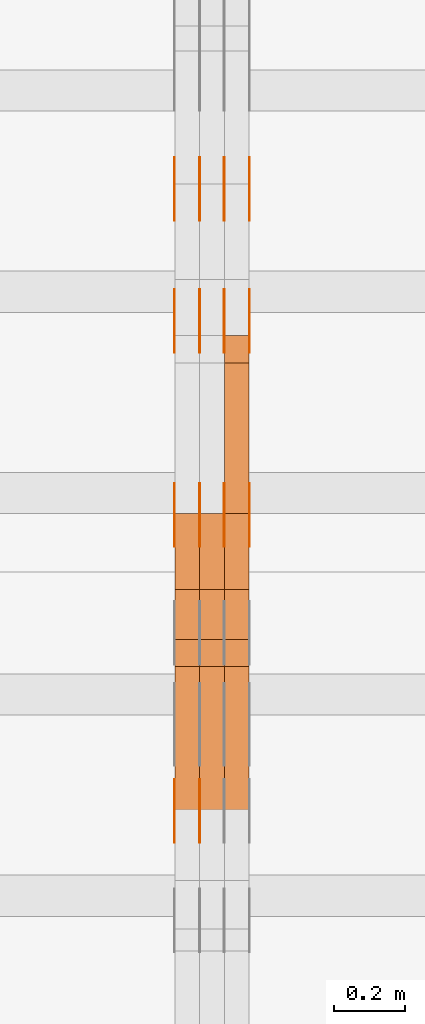
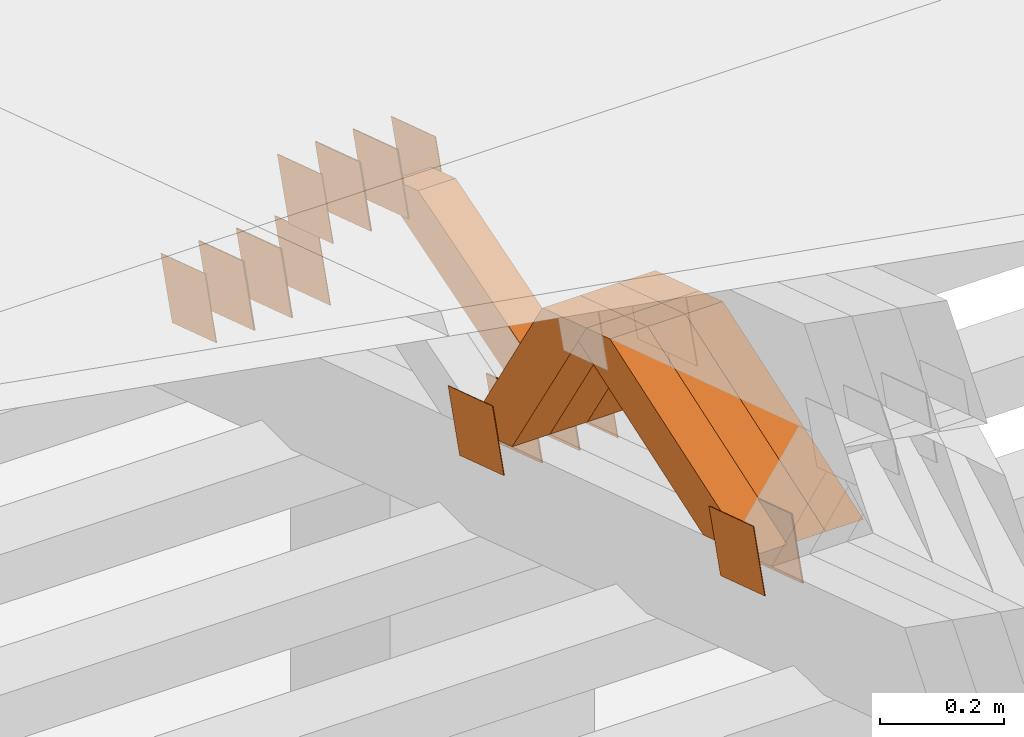
# One storey, part 356 of 385: 28 proxies.
"""IFC2X3 building model written with IfcOpenShell, lengths in millimetres."""

from ifc_helpers import new_model, entity, si_unit, converted_unit, derived_unit, direction, frame, origin, place, context, subcontext, project, spatial, polyline, outline, extrude, source, transform, mapped, material, type_object, type_shapes, element, save


model = new_model("IFC2X3")

# Units and contexts
model_context = context("Model", 3, precision=0.01, world=origin(), true_north=direction((6.12303176911189e-17, 1.0)))
body_context = subcontext(model_context, "Body", "Model", "MODEL_VIEW")
ifc_project = project(units=[si_unit("LENGTHUNIT", "METRE", prefix="MILLI"), si_unit("AREAUNIT", "SQUARE_METRE"), si_unit("VOLUMEUNIT", "CUBIC_METRE"), converted_unit("PLANEANGLEUNIT", "DEGREE", entity("IfcRatioMeasure", 0.0174532925199433), si_unit("PLANEANGLEUNIT", "RADIAN"), dimensions=[0, 0, 0, 0, 0, 0, 0]), si_unit("MASSUNIT", "GRAM", prefix="KILO"), derived_unit("MASSDENSITYUNIT", [(si_unit("MASSUNIT", "GRAM", prefix="KILO"), 1), (si_unit("LENGTHUNIT", "METRE"), -3)]), si_unit("TIMEUNIT", "SECOND"), si_unit("FREQUENCYUNIT", "HERTZ"), si_unit("THERMODYNAMICTEMPERATUREUNIT", "DEGREE_CELSIUS"), derived_unit("THERMALTRANSMITTANCEUNIT", [(si_unit("MASSUNIT", "GRAM", prefix="KILO"), 1), (si_unit("THERMODYNAMICTEMPERATUREUNIT", "KELVIN"), -1), (si_unit("TIMEUNIT", "SECOND"), -3)]), derived_unit("VOLUMETRICFLOWRATEUNIT", [(si_unit("LENGTHUNIT", "METRE"), 3), (si_unit("TIMEUNIT", "SECOND"), -1)]), si_unit("ELECTRICCURRENTUNIT", "AMPERE"), si_unit("ELECTRICVOLTAGEUNIT", "VOLT"), si_unit("POWERUNIT", "WATT"), si_unit("FORCEUNIT", "NEWTON", prefix="KILO"), si_unit("ILLUMINANCEUNIT", "LUX"), si_unit("LUMINOUSFLUXUNIT", "LUMEN"), si_unit("LUMINOUSINTENSITYUNIT", "CANDELA"), derived_unit("USERDEFINED", [(si_unit("MASSUNIT", "GRAM", prefix="KILO"), -1), (si_unit("LENGTHUNIT", "METRE"), -2), (si_unit("TIMEUNIT", "SECOND"), 3), (si_unit("LUMINOUSFLUXUNIT", "LUMEN"), 1)]), derived_unit("LINEARVELOCITYUNIT", [(si_unit("LENGTHUNIT", "METRE"), 1), (si_unit("TIMEUNIT", "SECOND"), -1)]), si_unit("PRESSUREUNIT", "PASCAL"), derived_unit("USERDEFINED", [(si_unit("LENGTHUNIT", "METRE"), -2), (si_unit("MASSUNIT", "GRAM", prefix="KILO"), 1), (si_unit("TIMEUNIT", "SECOND"), -2)])], contexts=[model_context])

# Site, building, storey
site_placement = place(None, origin())
site = spatial("IfcSite", under=ifc_project, at=site_placement, CompositionType="ELEMENT")
building_placement = place(site_placement, origin())
building = spatial("IfcBuilding", under=site, at=building_placement, CompositionType="ELEMENT")
storey_placement = place(building_placement, origin())
storey = spatial("IfcBuildingStorey", under=building, at=storey_placement, Name="Default", CompositionType="ELEMENT", Elevation=0.0)

# Proxies
ifc_material_1 = material(Name="IfcSurfaceStyle #548159")
building_element_proxy_type_1 = type_object("IfcBuildingElementProxyType", PredefinedType="NOTDEFINED", material=ifc_material_1)
shared_shape_1 = source(origin(), body_context, "Body", "SweptSolid", [
    extrude(outline(polyline([(-74.9998605591118, -59.9999264677598), (74.9998754286171, -59.9999264677598), (74.9998605591136, 59.9999264677598), (-74.9998754286189, 59.9999264677598), (-74.9998605591118, -59.9999264677598)])), frame((75.0000347664736, 60.0000016373434, 0.0), z_axis=(0.0, 0.0, 1.0), x_axis=(-1.0, 0.0, 0.0)), (0.0, 0.0, 1.0), 1.29999999999999),
])
type_shapes(building_element_proxy_type_1, [shared_shape_1])
proxy_1_placement = place(building_placement, frame((45245.0, 20117.0890328686, 2105.40814929196), z_axis=(-1.0, 0.0, 0.0), x_axis=(0.0, -0.951056516295124, 0.309016994375039)))
element("IfcBuildingElementProxy", 1, at=proxy_1_placement, inside=storey, type_object=building_element_proxy_type_1, material=ifc_material_1, context=body_context, shape_type="MappedRepresentation", body=[
    mapped(shared_shape_1, transform((0.0, 0.0, 0.0), scale=1.0)),
])
ifc_material_2 = material(Name="IfcSurfaceStyle #548102")
building_element_proxy_type_2 = type_object("IfcBuildingElementProxyType", PredefinedType="NOTDEFINED", material=ifc_material_2)
shared_shape_2 = source(origin(), body_context, "Body", "SweptSolid", [
    extrude(outline(polyline([(-74.9998605591118, -59.9999264677598), (74.9998754286171, -59.9999264677598), (74.9998605591136, 59.9999264677598), (-74.9998754286189, 59.9999264677598), (-74.9998605591118, -59.9999264677598)])), frame((75.0000347664736, 60.0000016373434, 0.0), z_axis=(0.0, 0.0, 1.0), x_axis=(-1.0, 0.0, 0.0)), (0.0, 0.0, 1.0), 1.29999999999999),
])
type_shapes(building_element_proxy_type_2, [shared_shape_2])
proxy_2_placement = place(building_placement, frame((45246.3, 20117.0890328686, 2105.40814929196), z_axis=(-1.0, 0.0, 0.0), x_axis=(0.0, -0.951056516295124, 0.309016994375039)))
element("IfcBuildingElementProxy", 2, at=proxy_2_placement, inside=storey, type_object=building_element_proxy_type_2, material=ifc_material_2, context=body_context, shape_type="MappedRepresentation", body=[
    mapped(shared_shape_2, transform((0.0, 0.0, 0.0), scale=1.0)),
])
ifc_material_3 = material(Name="IfcSurfaceStyle #548045")
building_element_proxy_type_3 = type_object("IfcBuildingElementProxyType", PredefinedType="NOTDEFINED", material=ifc_material_3)
shared_shape_3 = source(origin(), body_context, "Body", "SweptSolid", [
    extrude(outline(polyline([(-74.9998605591118, -59.9999264677598), (74.9998754286171, -59.9999264677598), (74.9998605591136, 59.9999264677598), (-74.9998754286189, 59.9999264677598), (-74.9998605591118, -59.9999264677598)])), frame((75.0000347664736, 60.0000016373434, 0.0), z_axis=(0.0, 0.0, 1.0), x_axis=(-1.0, 0.0, 0.0)), (0.0, 0.0, 1.0), 1.29999999999999),
])
type_shapes(building_element_proxy_type_3, [shared_shape_3])
proxy_3_placement = place(building_placement, frame((45175.0, 20117.0890328686, 2105.40814929196), z_axis=(-1.0, 0.0, 0.0), x_axis=(0.0, -0.951056516295124, 0.309016994375039)))
element("IfcBuildingElementProxy", 3, at=proxy_3_placement, inside=storey, type_object=building_element_proxy_type_3, material=ifc_material_3, context=body_context, shape_type="MappedRepresentation", body=[
    mapped(shared_shape_3, transform((0.0, 0.0, 0.0), scale=1.0)),
])
ifc_material_4 = material(Name="IfcSurfaceStyle #547988")
building_element_proxy_type_4 = type_object("IfcBuildingElementProxyType", PredefinedType="NOTDEFINED", material=ifc_material_4)
shared_shape_4 = source(origin(), body_context, "Body", "SweptSolid", [
    extrude(outline(polyline([(-74.9998794200132, -59.999984515643), (74.9998565677174, -59.999984515643), (74.9998794200123, 59.999984515643), (-74.9998565677165, 59.999984515643), (-74.9998794200132, -59.999984515643)])), frame((75.0002235343086, 60.0000596852268, 0.0), z_axis=(0.0, 0.0, 1.0), x_axis=(-1.0, 0.0, 0.0)), (0.0, 0.0, 1.0), 1.3),
])
type_shapes(building_element_proxy_type_4, [shared_shape_4])
proxy_4_placement = place(building_placement, frame((45386.3, 20956.2317725847, 1832.75404405346), z_axis=(-1.0, 0.0, 0.0), x_axis=(0.0, -0.951056516295124, 0.309016994375039)))
element("IfcBuildingElementProxy", 4, at=proxy_4_placement, inside=storey, type_object=building_element_proxy_type_4, material=ifc_material_4, context=body_context, shape_type="MappedRepresentation", body=[
    mapped(shared_shape_4, transform((0.0, 0.0, 0.0), scale=1.0)),
])
ifc_material_5 = material(Name="IfcSurfaceStyle #547931")
building_element_proxy_type_5 = type_object("IfcBuildingElementProxyType", PredefinedType="NOTDEFINED", material=ifc_material_5)
shared_shape_5 = source(origin(), body_context, "Body", "SweptSolid", [
    extrude(outline(polyline([(-74.9998794200132, -59.999984515643), (74.9998565677174, -59.999984515643), (74.9998794200123, 59.999984515643), (-74.9998565677165, 59.999984515643), (-74.9998794200132, -59.999984515643)])), frame((75.0002235343086, 60.0000596852268, 0.0), z_axis=(0.0, 0.0, 1.0), x_axis=(-1.0, 0.0, 0.0)), (0.0, 0.0, 1.0), 1.3),
])
type_shapes(building_element_proxy_type_5, [shared_shape_5])
proxy_5_placement = place(building_placement, frame((45315.0, 20956.2317725847, 1832.75404405346), z_axis=(-1.0, 0.0, 0.0), x_axis=(0.0, -0.951056516295124, 0.309016994375039)))
element("IfcBuildingElementProxy", 5, at=proxy_5_placement, inside=storey, type_object=building_element_proxy_type_5, material=ifc_material_5, context=body_context, shape_type="MappedRepresentation", body=[
    mapped(shared_shape_5, transform((0.0, 0.0, 0.0), scale=1.0)),
])
ifc_material_6 = material(Name="IfcSurfaceStyle #547874")
building_element_proxy_type_6 = type_object("IfcBuildingElementProxyType", PredefinedType="NOTDEFINED", material=ifc_material_6)
shared_shape_6 = source(origin(), body_context, "Body", "SweptSolid", [
    extrude(outline(polyline([(-74.9998794200132, -59.999984515643), (74.9998565677174, -59.999984515643), (74.9998794200123, 59.999984515643), (-74.9998565677165, 59.999984515643), (-74.9998794200132, -59.999984515643)])), frame((75.0002235343086, 60.0000596852268, 0.0), z_axis=(0.0, 0.0, 1.0), x_axis=(-1.0, 0.0, 0.0)), (0.0, 0.0, 1.0), 1.3),
])
type_shapes(building_element_proxy_type_6, [shared_shape_6])
proxy_6_placement = place(building_placement, frame((45316.3, 20956.2317725847, 1832.75404405346), z_axis=(-1.0, 0.0, 0.0), x_axis=(0.0, -0.951056516295124, 0.309016994375039)))
element("IfcBuildingElementProxy", 6, at=proxy_6_placement, inside=storey, type_object=building_element_proxy_type_6, material=ifc_material_6, context=body_context, shape_type="MappedRepresentation", body=[
    mapped(shared_shape_6, transform((0.0, 0.0, 0.0), scale=1.0)),
])
ifc_material_7 = material(Name="IfcSurfaceStyle #547817")
building_element_proxy_type_7 = type_object("IfcBuildingElementProxyType", PredefinedType="NOTDEFINED", material=ifc_material_7)
shared_shape_7 = source(origin(), body_context, "Body", "SweptSolid", [
    extrude(outline(polyline([(-74.9998794200132, -59.999984515643), (74.9998565677174, -59.999984515643), (74.9998794200123, 59.999984515643), (-74.9998565677165, 59.999984515643), (-74.9998794200132, -59.999984515643)])), frame((75.0002235343086, 60.0000596852268, 0.0), z_axis=(0.0, 0.0, 1.0), x_axis=(-1.0, 0.0, 0.0)), (0.0, 0.0, 1.0), 1.29999999999999),
])
type_shapes(building_element_proxy_type_7, [shared_shape_7])
proxy_7_placement = place(building_placement, frame((45245.0, 20956.2317725847, 1832.75404405346), z_axis=(-1.0, 0.0, 0.0), x_axis=(0.0, -0.951056516295124, 0.309016994375039)))
element("IfcBuildingElementProxy", 7, at=proxy_7_placement, inside=storey, type_object=building_element_proxy_type_7, material=ifc_material_7, context=body_context, shape_type="MappedRepresentation", body=[
    mapped(shared_shape_7, transform((0.0, 0.0, 0.0), scale=1.0)),
])
ifc_material_8 = material(Name="IfcSurfaceStyle #547760")
building_element_proxy_type_8 = type_object("IfcBuildingElementProxyType", PredefinedType="NOTDEFINED", material=ifc_material_8)
shared_shape_8 = source(origin(), body_context, "Body", "SweptSolid", [
    extrude(outline(polyline([(-74.9998794200132, -59.999984515643), (74.9998565677174, -59.999984515643), (74.9998794200123, 59.999984515643), (-74.9998565677165, 59.999984515643), (-74.9998794200132, -59.999984515643)])), frame((75.0002235343086, 60.0000596852268, 0.0), z_axis=(0.0, 0.0, 1.0), x_axis=(-1.0, 0.0, 0.0)), (0.0, 0.0, 1.0), 1.29999999999999),
])
type_shapes(building_element_proxy_type_8, [shared_shape_8])
proxy_8_placement = place(building_placement, frame((45246.3, 20956.2317725847, 1832.75404405346), z_axis=(-1.0, 0.0, 0.0), x_axis=(0.0, -0.951056516295124, 0.309016994375039)))
element("IfcBuildingElementProxy", 8, at=proxy_8_placement, inside=storey, type_object=building_element_proxy_type_8, material=ifc_material_8, context=body_context, shape_type="MappedRepresentation", body=[
    mapped(shared_shape_8, transform((0.0, 0.0, 0.0), scale=1.0)),
])
ifc_material_9 = material(Name="IfcSurfaceStyle #547703")
building_element_proxy_type_9 = type_object("IfcBuildingElementProxyType", PredefinedType="NOTDEFINED", material=ifc_material_9)
shared_shape_9 = source(origin(), body_context, "Body", "SweptSolid", [
    extrude(outline(polyline([(-74.9998794200132, -59.999984515643), (74.9998565677174, -59.999984515643), (74.9998794200123, 59.999984515643), (-74.9998565677165, 59.999984515643), (-74.9998794200132, -59.999984515643)])), frame((75.0002235343086, 60.0000596852268, 0.0), z_axis=(0.0, 0.0, 1.0), x_axis=(-1.0, 0.0, 0.0)), (0.0, 0.0, 1.0), 1.29999999999999),
])
type_shapes(building_element_proxy_type_9, [shared_shape_9])
proxy_9_placement = place(building_placement, frame((45175.0, 20956.2317725847, 1832.75404405346), z_axis=(-1.0, 0.0, 0.0), x_axis=(0.0, -0.951056516295124, 0.309016994375039)))
element("IfcBuildingElementProxy", 9, at=proxy_9_placement, inside=storey, type_object=building_element_proxy_type_9, material=ifc_material_9, context=body_context, shape_type="MappedRepresentation", body=[
    mapped(shared_shape_9, transform((0.0, 0.0, 0.0), scale=1.0)),
])
ifc_material_10 = material(Name="IfcSurfaceStyle #547646")
building_element_proxy_type_10 = type_object("IfcBuildingElementProxyType", PredefinedType="NOTDEFINED", material=ifc_material_10)
shared_shape_10 = source(origin(), body_context, "Body", "SweptSolid", [
    extrude(outline(polyline([(-75.0001116115454, -60.0000599592451), (75.0000887592496, -60.0000599592451), (75.0001116115454, 60.0000599592451), (-75.0000887592496, 60.0000599592451), (-75.0001116115454, -60.0000599592451)])), frame((75.0001116115454, 60.0000599592451, 0.0), z_axis=(0.0, 0.0, 1.0), x_axis=(-1.0, 0.0, 0.0)), (0.0, 0.0, 1.0), 1.3),
])
type_shapes(building_element_proxy_type_10, [shared_shape_10])
proxy_10_placement = place(building_placement, frame((45386.3, 21881.0815195707, 1532.2522473242), z_axis=(-1.0, 0.0, 0.0), x_axis=(0.0, -0.951056516295124, 0.309016994375039)))
element("IfcBuildingElementProxy", 10, at=proxy_10_placement, inside=storey, type_object=building_element_proxy_type_10, material=ifc_material_10, context=body_context, shape_type="MappedRepresentation", body=[
    mapped(shared_shape_10, transform((0.0, 0.0, 0.0), scale=1.0)),
])
ifc_material_11 = material(Name="IfcSurfaceStyle #547589")
building_element_proxy_type_11 = type_object("IfcBuildingElementProxyType", PredefinedType="NOTDEFINED", material=ifc_material_11)
shared_shape_11 = source(origin(), body_context, "Body", "SweptSolid", [
    extrude(outline(polyline([(-75.0001116115454, -60.0000599592451), (75.0000887592496, -60.0000599592451), (75.0001116115454, 60.0000599592451), (-75.0000887592496, 60.0000599592451), (-75.0001116115454, -60.0000599592451)])), frame((75.0001116115454, 60.0000599592451, 0.0), z_axis=(0.0, 0.0, 1.0), x_axis=(-1.0, 0.0, 0.0)), (0.0, 0.0, 1.0), 1.3),
])
type_shapes(building_element_proxy_type_11, [shared_shape_11])
proxy_11_placement = place(building_placement, frame((45315.0, 21881.0815195707, 1532.2522473242), z_axis=(-1.0, 0.0, 0.0), x_axis=(0.0, -0.951056516295124, 0.309016994375039)))
element("IfcBuildingElementProxy", 11, at=proxy_11_placement, inside=storey, type_object=building_element_proxy_type_11, material=ifc_material_11, context=body_context, shape_type="MappedRepresentation", body=[
    mapped(shared_shape_11, transform((0.0, 0.0, 0.0), scale=1.0)),
])
ifc_material_12 = material(Name="IfcSurfaceStyle #547532")
building_element_proxy_type_12 = type_object("IfcBuildingElementProxyType", PredefinedType="NOTDEFINED", material=ifc_material_12)
shared_shape_12 = source(origin(), body_context, "Body", "SweptSolid", [
    extrude(outline(polyline([(-75.0001116115454, -60.0000599592451), (75.0000887592496, -60.0000599592451), (75.0001116115454, 60.0000599592451), (-75.0000887592496, 60.0000599592451), (-75.0001116115454, -60.0000599592451)])), frame((75.0001116115454, 60.0000599592451, 0.0), z_axis=(0.0, 0.0, 1.0), x_axis=(-1.0, 0.0, 0.0)), (0.0, 0.0, 1.0), 1.3),
])
type_shapes(building_element_proxy_type_12, [shared_shape_12])
proxy_12_placement = place(building_placement, frame((45316.3, 21881.0815195707, 1532.2522473242), z_axis=(-1.0, 0.0, 0.0), x_axis=(0.0, -0.951056516295124, 0.309016994375039)))
element("IfcBuildingElementProxy", 12, at=proxy_12_placement, inside=storey, type_object=building_element_proxy_type_12, material=ifc_material_12, context=body_context, shape_type="MappedRepresentation", body=[
    mapped(shared_shape_12, transform((0.0, 0.0, 0.0), scale=1.0)),
])
ifc_material_13 = material(Name="IfcSurfaceStyle #547475")
building_element_proxy_type_13 = type_object("IfcBuildingElementProxyType", PredefinedType="NOTDEFINED", material=ifc_material_13)
shared_shape_13 = source(origin(), body_context, "Body", "SweptSolid", [
    extrude(outline(polyline([(-75.0001116115454, -60.0000599592451), (75.0000887592496, -60.0000599592451), (75.0001116115454, 60.0000599592451), (-75.0000887592496, 60.0000599592451), (-75.0001116115454, -60.0000599592451)])), frame((75.0001116115454, 60.0000599592451, 0.0), z_axis=(0.0, 0.0, 1.0), x_axis=(-1.0, 0.0, 0.0)), (0.0, 0.0, 1.0), 1.29999999999999),
])
type_shapes(building_element_proxy_type_13, [shared_shape_13])
proxy_13_placement = place(building_placement, frame((45245.0, 21881.0815195707, 1532.2522473242), z_axis=(-1.0, 0.0, 0.0), x_axis=(0.0, -0.951056516295124, 0.309016994375039)))
element("IfcBuildingElementProxy", 13, at=proxy_13_placement, inside=storey, type_object=building_element_proxy_type_13, material=ifc_material_13, context=body_context, shape_type="MappedRepresentation", body=[
    mapped(shared_shape_13, transform((0.0, 0.0, 0.0), scale=1.0)),
])
ifc_material_14 = material(Name="IfcSurfaceStyle #547418")
building_element_proxy_type_14 = type_object("IfcBuildingElementProxyType", PredefinedType="NOTDEFINED", material=ifc_material_14)
shared_shape_14 = source(origin(), body_context, "Body", "SweptSolid", [
    extrude(outline(polyline([(-75.0001116115454, -60.0000599592451), (75.0000887592496, -60.0000599592451), (75.0001116115454, 60.0000599592451), (-75.0000887592496, 60.0000599592451), (-75.0001116115454, -60.0000599592451)])), frame((75.0001116115454, 60.0000599592451, 0.0), z_axis=(0.0, 0.0, 1.0), x_axis=(-1.0, 0.0, 0.0)), (0.0, 0.0, 1.0), 1.29999999999999),
])
type_shapes(building_element_proxy_type_14, [shared_shape_14])
proxy_14_placement = place(building_placement, frame((45246.3, 21881.0815195707, 1532.2522473242), z_axis=(-1.0, 0.0, 0.0), x_axis=(0.0, -0.951056516295124, 0.309016994375039)))
element("IfcBuildingElementProxy", 14, at=proxy_14_placement, inside=storey, type_object=building_element_proxy_type_14, material=ifc_material_14, context=body_context, shape_type="MappedRepresentation", body=[
    mapped(shared_shape_14, transform((0.0, 0.0, 0.0), scale=1.0)),
])
ifc_material_15 = material(Name="IfcSurfaceStyle #547361")
building_element_proxy_type_15 = type_object("IfcBuildingElementProxyType", PredefinedType="NOTDEFINED", material=ifc_material_15)
shared_shape_15 = source(origin(), body_context, "Body", "SweptSolid", [
    extrude(outline(polyline([(-75.0001116115454, -60.0000599592451), (75.0000887592496, -60.0000599592451), (75.0001116115454, 60.0000599592451), (-75.0000887592496, 60.0000599592451), (-75.0001116115454, -60.0000599592451)])), frame((75.0001116115454, 60.0000599592451, 0.0), z_axis=(0.0, 0.0, 1.0), x_axis=(-1.0, 0.0, 0.0)), (0.0, 0.0, 1.0), 1.29999999999999),
])
type_shapes(building_element_proxy_type_15, [shared_shape_15])
proxy_15_placement = place(building_placement, frame((45175.0, 21881.0815195707, 1532.2522473242), z_axis=(-1.0, 0.0, 0.0), x_axis=(0.0, -0.951056516295124, 0.309016994375039)))
element("IfcBuildingElementProxy", 15, at=proxy_15_placement, inside=storey, type_object=building_element_proxy_type_15, material=ifc_material_15, context=body_context, shape_type="MappedRepresentation", body=[
    mapped(shared_shape_15, transform((0.0, 0.0, 0.0), scale=1.0)),
])
ifc_material_16 = material(Name="IfcSurfaceStyle #542174")
building_element_proxy_type_16 = type_object("IfcBuildingElementProxyType", PredefinedType="NOTDEFINED", material=ifc_material_16)
shared_shape_16 = source(origin(), body_context, "Body", "SweptSolid", [
    extrude(outline(polyline([(-74.9998794200064, -59.9999845156358), (74.9998565677224, -59.9999845156358), (74.9998794200064, 59.9999845156358), (-74.9998565677224, 59.9999845156358), (-74.9998794200064, -59.9999845156358)])), frame((74.9999765995044, 60.0000596852337, 0.0), z_axis=(0.0, 0.0, 1.0), x_axis=(-1.0, 0.0, 0.0)), (0.0, 0.0, 1.0), 1.3),
])
type_shapes(building_element_proxy_type_16, [shared_shape_16])
proxy_16_placement = place(building_placement, frame((45386.3, 21505.9776314857, 1954.5332951652), z_axis=(-1.0, 0.0, 0.0), x_axis=(0.0, -0.951056516295154, 0.309016994374948)))
element("IfcBuildingElementProxy", 16, at=proxy_16_placement, inside=storey, type_object=building_element_proxy_type_16, material=ifc_material_16, context=body_context, shape_type="MappedRepresentation", body=[
    mapped(shared_shape_16, transform((0.0, 0.0, 0.0), scale=1.0)),
])
ifc_material_17 = material(Name="IfcSurfaceStyle #542117")
building_element_proxy_type_17 = type_object("IfcBuildingElementProxyType", PredefinedType="NOTDEFINED", material=ifc_material_17)
shared_shape_17 = source(origin(), body_context, "Body", "SweptSolid", [
    extrude(outline(polyline([(-74.9998794200064, -59.9999845156358), (74.9998565677224, -59.9999845156358), (74.9998794200064, 59.9999845156358), (-74.9998565677224, 59.9999845156358), (-74.9998794200064, -59.9999845156358)])), frame((74.9999765995044, 60.0000596852337, 0.0), z_axis=(0.0, 0.0, 1.0), x_axis=(-1.0, 0.0, 0.0)), (0.0, 0.0, 1.0), 1.3),
])
type_shapes(building_element_proxy_type_17, [shared_shape_17])
proxy_17_placement = place(building_placement, frame((45315.0, 21505.9776314857, 1954.5332951652), z_axis=(-1.0, 0.0, 0.0), x_axis=(0.0, -0.951056516295154, 0.309016994374948)))
element("IfcBuildingElementProxy", 17, at=proxy_17_placement, inside=storey, type_object=building_element_proxy_type_17, material=ifc_material_17, context=body_context, shape_type="MappedRepresentation", body=[
    mapped(shared_shape_17, transform((0.0, 0.0, 0.0), scale=1.0)),
])
ifc_material_18 = material(Name="IfcSurfaceStyle #542060")
building_element_proxy_type_18 = type_object("IfcBuildingElementProxyType", PredefinedType="NOTDEFINED", material=ifc_material_18)
shared_shape_18 = source(origin(), body_context, "Body", "SweptSolid", [
    extrude(outline(polyline([(-74.9998794200064, -59.9999845156358), (74.9998565677224, -59.9999845156358), (74.9998794200064, 59.9999845156358), (-74.9998565677224, 59.9999845156358), (-74.9998794200064, -59.9999845156358)])), frame((74.9999765995044, 60.0000596852337, 0.0), z_axis=(0.0, 0.0, 1.0), x_axis=(-1.0, 0.0, 0.0)), (0.0, 0.0, 1.0), 1.3),
])
type_shapes(building_element_proxy_type_18, [shared_shape_18])
proxy_18_placement = place(building_placement, frame((45316.3, 21505.9776314857, 1954.5332951652), z_axis=(-1.0, 0.0, 0.0), x_axis=(0.0, -0.951056516295154, 0.309016994374948)))
element("IfcBuildingElementProxy", 18, at=proxy_18_placement, inside=storey, type_object=building_element_proxy_type_18, material=ifc_material_18, context=body_context, shape_type="MappedRepresentation", body=[
    mapped(shared_shape_18, transform((0.0, 0.0, 0.0), scale=1.0)),
])
ifc_material_19 = material(Name="IfcSurfaceStyle #542003")
building_element_proxy_type_19 = type_object("IfcBuildingElementProxyType", PredefinedType="NOTDEFINED", material=ifc_material_19)
shared_shape_19 = source(origin(), body_context, "Body", "SweptSolid", [
    extrude(outline(polyline([(-74.9998794200064, -59.9999845156358), (74.9998565677224, -59.9999845156358), (74.9998794200064, 59.9999845156358), (-74.9998565677224, 59.9999845156358), (-74.9998794200064, -59.9999845156358)])), frame((74.9999765995044, 60.0000596852337, 0.0), z_axis=(0.0, 0.0, 1.0), x_axis=(-1.0, 0.0, 0.0)), (0.0, 0.0, 1.0), 1.29999999999999),
])
type_shapes(building_element_proxy_type_19, [shared_shape_19])
proxy_19_placement = place(building_placement, frame((45245.0, 21505.9776314857, 1954.5332951652), z_axis=(-1.0, 0.0, 0.0), x_axis=(0.0, -0.951056516295154, 0.309016994374948)))
element("IfcBuildingElementProxy", 19, at=proxy_19_placement, inside=storey, type_object=building_element_proxy_type_19, material=ifc_material_19, context=body_context, shape_type="MappedRepresentation", body=[
    mapped(shared_shape_19, transform((0.0, 0.0, 0.0), scale=1.0)),
])
ifc_material_20 = material(Name="IfcSurfaceStyle #541946")
building_element_proxy_type_20 = type_object("IfcBuildingElementProxyType", PredefinedType="NOTDEFINED", material=ifc_material_20)
shared_shape_20 = source(origin(), body_context, "Body", "SweptSolid", [
    extrude(outline(polyline([(-74.9998794200064, -59.9999845156358), (74.9998565677224, -59.9999845156358), (74.9998794200064, 59.9999845156358), (-74.9998565677224, 59.9999845156358), (-74.9998794200064, -59.9999845156358)])), frame((74.9999765995044, 60.0000596852337, 0.0), z_axis=(0.0, 0.0, 1.0), x_axis=(-1.0, 0.0, 0.0)), (0.0, 0.0, 1.0), 1.29999999999999),
])
type_shapes(building_element_proxy_type_20, [shared_shape_20])
proxy_20_placement = place(building_placement, frame((45246.3, 21505.9776314857, 1954.5332951652), z_axis=(-1.0, 0.0, 0.0), x_axis=(0.0, -0.951056516295154, 0.309016994374948)))
element("IfcBuildingElementProxy", 20, at=proxy_20_placement, inside=storey, type_object=building_element_proxy_type_20, material=ifc_material_20, context=body_context, shape_type="MappedRepresentation", body=[
    mapped(shared_shape_20, transform((0.0, 0.0, 0.0), scale=1.0)),
])
ifc_material_21 = material(Name="IfcSurfaceStyle #541889")
building_element_proxy_type_21 = type_object("IfcBuildingElementProxyType", PredefinedType="NOTDEFINED", material=ifc_material_21)
shared_shape_21 = source(origin(), body_context, "Body", "SweptSolid", [
    extrude(outline(polyline([(-74.9998794200064, -59.9999845156358), (74.9998565677224, -59.9999845156358), (74.9998794200064, 59.9999845156358), (-74.9998565677224, 59.9999845156358), (-74.9998794200064, -59.9999845156358)])), frame((74.9999765995044, 60.0000596852337, 0.0), z_axis=(0.0, 0.0, 1.0), x_axis=(-1.0, 0.0, 0.0)), (0.0, 0.0, 1.0), 1.29999999999999),
])
type_shapes(building_element_proxy_type_21, [shared_shape_21])
proxy_21_placement = place(building_placement, frame((45175.0, 21505.9776314857, 1954.5332951652), z_axis=(-1.0, 0.0, 0.0), x_axis=(0.0, -0.951056516295154, 0.309016994374948)))
element("IfcBuildingElementProxy", 21, at=proxy_21_placement, inside=storey, type_object=building_element_proxy_type_21, material=ifc_material_21, context=body_context, shape_type="MappedRepresentation", body=[
    mapped(shared_shape_21, transform((0.0, 0.0, 0.0), scale=1.0)),
])
ifc_material_22 = material(Name="IfcSurfaceStyle #530726")
building_element_proxy_type_22 = type_object("IfcBuildingElementProxyType", Name="T1-W26 530724", PredefinedType="NOTDEFINED", material=ifc_material_22)
shared_shape_22 = source(origin(), body_context, "Body", "SweptSolid", [
    extrude(outline(polyline([(-339.390941716546, -47.5001331548025), (137.738864791781, -47.5001331548025), (201.272298560955, 6.02772073885038e-05), (212.703852542003, 47.5001030161988), (-212.324074178193, 47.5001030161988), (-339.390941716546, -47.5001331548025)])), frame((212.703852542003, 47.5001030161988, 0.0), z_axis=(0.0, 0.0, 1.0), x_axis=(-1.0, 0.0, 0.0)), (0.0, 0.0, 1.0), 70.0),
])
type_shapes(building_element_proxy_type_22, [shared_shape_22])
proxy_22_placement = place(building_placement, frame((45385.0, 20576.541015625, 2286.80981445313), z_axis=(-1.0, 0.0, 0.0), x_axis=(0.0, -0.946743816465327, -0.321987804093053)))
element("IfcBuildingElementProxy", 22, at=proxy_22_placement, inside=storey, type_object=building_element_proxy_type_22, material=ifc_material_22, Name="T1-W26", context=body_context, shape_type="MappedRepresentation", body=[
    mapped(shared_shape_22, transform((0.0, 0.0, 0.0), scale=1.0)),
])
ifc_material_23 = material(Name="IfcSurfaceStyle #530660")
building_element_proxy_type_23 = type_object("IfcBuildingElementProxyType", Name="T1-W26 530658", PredefinedType="NOTDEFINED", material=ifc_material_23)
shared_shape_23 = source(origin(), body_context, "Body", "SweptSolid", [
    extrude(outline(polyline([(-339.390941716546, -47.5001331548025), (137.738864791781, -47.5001331548025), (201.272298560955, 6.02772073885038e-05), (212.703852542003, 47.5001030161988), (-212.324074178193, 47.5001030161988), (-339.390941716546, -47.5001331548025)])), frame((212.703852542003, 47.5001030161988, 0.0), z_axis=(0.0, 0.0, 1.0), x_axis=(-1.0, 0.0, 0.0)), (0.0, 0.0, 1.0), 70.0),
])
type_shapes(building_element_proxy_type_23, [shared_shape_23])
proxy_23_placement = place(building_placement, frame((45315.0, 20576.541015625, 2286.80981445313), z_axis=(-1.0, 0.0, 0.0), x_axis=(0.0, -0.946743816465327, -0.321987804093053)))
element("IfcBuildingElementProxy", 23, at=proxy_23_placement, inside=storey, type_object=building_element_proxy_type_23, material=ifc_material_23, Name="T1-W26", context=body_context, shape_type="MappedRepresentation", body=[
    mapped(shared_shape_23, transform((0.0, 0.0, 0.0), scale=1.0)),
])
ifc_material_24 = material(Name="IfcSurfaceStyle #530594")
building_element_proxy_type_24 = type_object("IfcBuildingElementProxyType", Name="T1-W26 530592", PredefinedType="NOTDEFINED", material=ifc_material_24)
shared_shape_24 = source(origin(), body_context, "Body", "SweptSolid", [
    extrude(outline(polyline([(-339.390941716546, -47.5001331548025), (137.738864791781, -47.5001331548025), (201.272298560955, 6.02772073885038e-05), (212.703852542003, 47.5001030161988), (-212.324074178193, 47.5001030161988), (-339.390941716546, -47.5001331548025)])), frame((212.703852542003, 47.5001030161988, 0.0), z_axis=(0.0, 0.0, 1.0), x_axis=(-1.0, 0.0, 0.0)), (0.0, 0.0, 1.0), 70.0),
])
type_shapes(building_element_proxy_type_24, [shared_shape_24])
proxy_24_placement = place(building_placement, frame((45245.0, 20576.541015625, 2286.80981445313), z_axis=(-1.0, 0.0, 0.0), x_axis=(0.0, -0.946743816465327, -0.321987804093053)))
element("IfcBuildingElementProxy", 24, at=proxy_24_placement, inside=storey, type_object=building_element_proxy_type_24, material=ifc_material_24, Name="T1-W26", context=body_context, shape_type="MappedRepresentation", body=[
    mapped(shared_shape_24, transform((0.0, 0.0, 0.0), scale=1.0)),
])
ifc_material_25 = material(Name="IfcSurfaceStyle #530330")
building_element_proxy_type_25 = type_object("IfcBuildingElementProxyType", Name="T1-W29 530328", PredefinedType="NOTDEFINED", material=ifc_material_25)
shared_shape_25 = source(origin(), body_context, "Body", "SweptSolid", [
    extrude(outline(polyline([(-202.325994317059, -47.5000867467013), (200.714255560873, -47.5000867467013), (187.834128885383, 0.000593513395139059), (130.590899902046, 47.4997899900038), (-316.813290031243, 47.4997899900038), (-202.325994317059, -47.5000867467013)])), frame((200.714255560873, 47.5001935424745, 0.0), z_axis=(0.0, 0.0, 1.0), x_axis=(-1.0, 0.0, 0.0)), (0.0, 0.0, 1.0), 70.0),
])
type_shapes(building_element_proxy_type_25, [shared_shape_25])
proxy_25_placement = place(building_placement, frame((45385.0, 20827.0771193222, 1890.72342063252), z_axis=(-1.0, 0.0, 0.0), x_axis=(0.0, -0.534567451138397, 0.845125813227473)))
element("IfcBuildingElementProxy", 25, at=proxy_25_placement, inside=storey, type_object=building_element_proxy_type_25, material=ifc_material_25, Name="T1-W29", context=body_context, shape_type="MappedRepresentation", body=[
    mapped(shared_shape_25, transform((0.0, 0.0, 0.0), scale=1.0)),
])
ifc_material_26 = material(Name="IfcSurfaceStyle #530264")
building_element_proxy_type_26 = type_object("IfcBuildingElementProxyType", Name="T1-W29 530262", PredefinedType="NOTDEFINED", material=ifc_material_26)
shared_shape_26 = source(origin(), body_context, "Body", "SweptSolid", [
    extrude(outline(polyline([(-202.325994317059, -47.5000867467013), (200.714255560873, -47.5000867467013), (187.834128885383, 0.000593513395139059), (130.590899902046, 47.4997899900038), (-316.813290031243, 47.4997899900038), (-202.325994317059, -47.5000867467013)])), frame((200.714255560873, 47.5001935424745, 0.0), z_axis=(0.0, 0.0, 1.0), x_axis=(-1.0, 0.0, 0.0)), (0.0, 0.0, 1.0), 70.0),
])
type_shapes(building_element_proxy_type_26, [shared_shape_26])
proxy_26_placement = place(building_placement, frame((45315.0, 20827.0771193222, 1890.72342063252), z_axis=(-1.0, 0.0, 0.0), x_axis=(0.0, -0.534567451138397, 0.845125813227473)))
element("IfcBuildingElementProxy", 26, at=proxy_26_placement, inside=storey, type_object=building_element_proxy_type_26, material=ifc_material_26, Name="T1-W29", context=body_context, shape_type="MappedRepresentation", body=[
    mapped(shared_shape_26, transform((0.0, 0.0, 0.0), scale=1.0)),
])
ifc_material_27 = material(Name="IfcSurfaceStyle #530198")
building_element_proxy_type_27 = type_object("IfcBuildingElementProxyType", Name="T1-W29 530196", PredefinedType="NOTDEFINED", material=ifc_material_27)
shared_shape_27 = source(origin(), body_context, "Body", "SweptSolid", [
    extrude(outline(polyline([(-202.325994317059, -47.5000867467013), (200.714255560873, -47.5000867467013), (187.834128885383, 0.000593513395139059), (130.590899902046, 47.4997899900038), (-316.813290031243, 47.4997899900038), (-202.325994317059, -47.5000867467013)])), frame((200.714255560873, 47.5001935424745, 0.0), z_axis=(0.0, 0.0, 1.0), x_axis=(-1.0, 0.0, 0.0)), (0.0, 0.0, 1.0), 70.0),
])
type_shapes(building_element_proxy_type_27, [shared_shape_27])
proxy_27_placement = place(building_placement, frame((45245.0, 20827.0771193222, 1890.72342063252), z_axis=(-1.0, 0.0, 0.0), x_axis=(0.0, -0.534567451138397, 0.845125813227473)))
element("IfcBuildingElementProxy", 27, at=proxy_27_placement, inside=storey, type_object=building_element_proxy_type_27, material=ifc_material_27, Name="T1-W29", context=body_context, shape_type="MappedRepresentation", body=[
    mapped(shared_shape_27, transform((0.0, 0.0, 0.0), scale=1.0)),
])
ifc_material_28 = material(Name="IfcSurfaceStyle #529934")
building_element_proxy_type_28 = type_object("IfcBuildingElementProxyType", Name="T1-W20 529932", PredefinedType="NOTDEFINED", material=ifc_material_28)
shared_shape_28 = source(origin(), body_context, "Body", "SweptSolid", [
    extrude(outline(polyline([(-355.264945969921, -47.5000317999193), (141.064821099313, -47.5000317999193), (208.541978467889, 8.19311626391928e-05), (225.96877763549, 47.499990834338), (-220.31063123277, 47.4999908343379), (-355.264945969921, -47.5000317999193)])), frame((225.968921063481, 47.5000683592689, 0.0), z_axis=(0.0, 0.0, 1.0), x_axis=(-1.0, 0.0, 0.0)), (0.0, 0.0, 1.0), 70.0),
])
type_shapes(building_element_proxy_type_28, [shared_shape_28])
proxy_28_placement = place(building_placement, frame((45385.0, 21443.7472302196, 2007.54830804072), z_axis=(-1.0, 0.0, 0.0), x_axis=(0.0, -0.95556995517236, -0.29476441571515)))
element("IfcBuildingElementProxy", 28, at=proxy_28_placement, inside=storey, type_object=building_element_proxy_type_28, material=ifc_material_28, Name="T1-W20", context=body_context, shape_type="MappedRepresentation", body=[
    mapped(shared_shape_28, transform((0.0, 0.0, 0.0), scale=1.0)),
])

save(model, "model.ifc")
